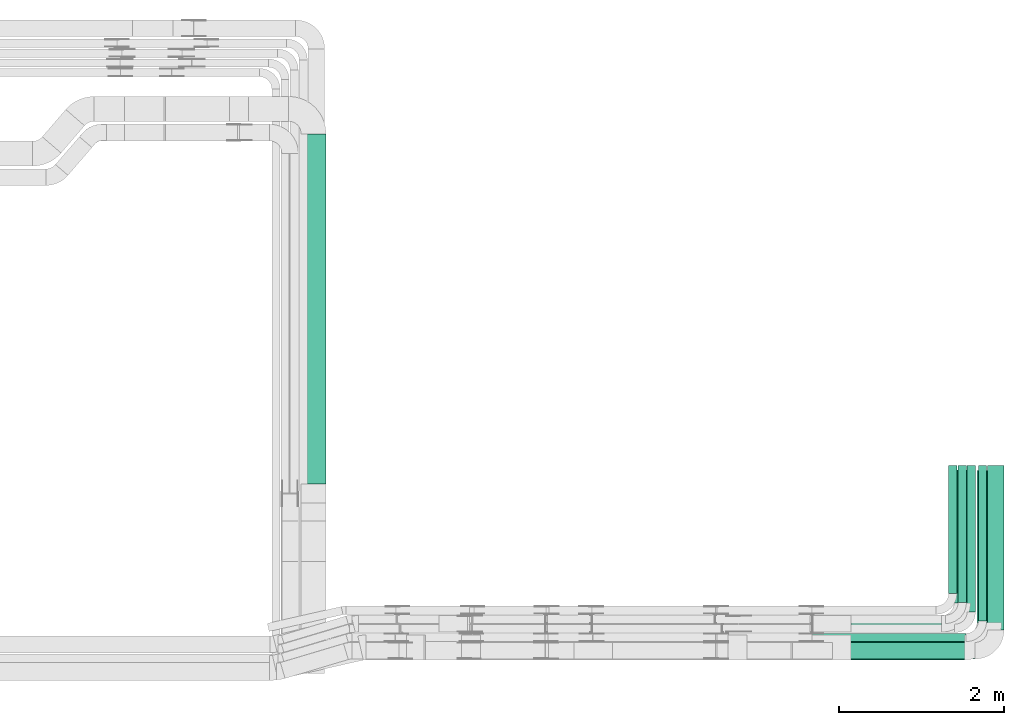
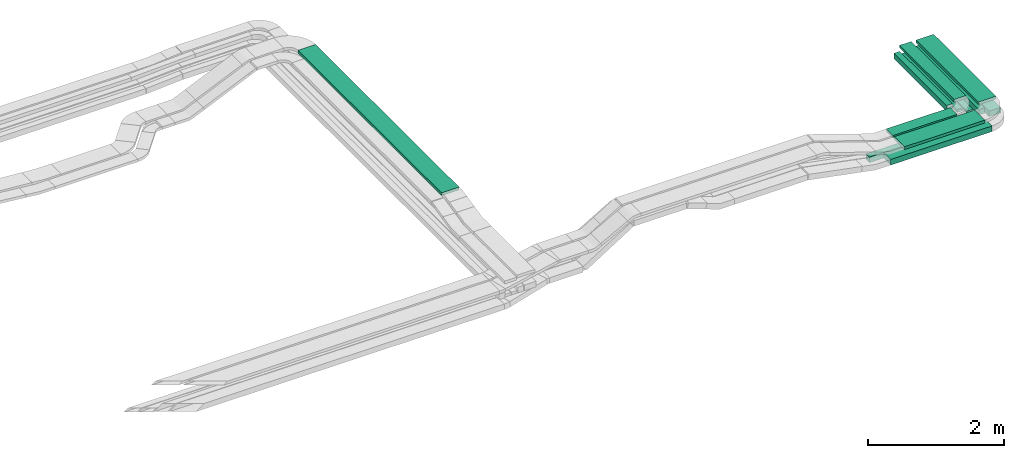
# One storey, part 3 of 28: 12 flow segments.
"""IFC2X3 building model written with IfcOpenShell, lengths in millimetres."""

from ifc_helpers import new_model, entity, si_unit, converted_unit, derived_unit, direction, frame, origin, origin_2d_with_axis, place, context, subcontext, project, spatial, rectangle, extrude, type_object, element, save


model = new_model("IFC2X3")

# Units and contexts
model_context = context("Model", 3, precision=0.01, world=origin(), true_north=direction((6.12303176911189e-17, 1.0)))
body_context = subcontext(model_context, "Body", "Model", "MODEL_VIEW")
ifc_project = project(units=[si_unit("LENGTHUNIT", "METRE", prefix="MILLI"), si_unit("AREAUNIT", "SQUARE_METRE"), si_unit("VOLUMEUNIT", "CUBIC_METRE"), converted_unit("PLANEANGLEUNIT", "DEGREE", entity("IfcRatioMeasure", 0.0174532925199433), si_unit("PLANEANGLEUNIT", "RADIAN"), dimensions=[0, 0, 0, 0, 0, 0, 0]), si_unit("MASSUNIT", "GRAM", prefix="KILO"), derived_unit("MASSDENSITYUNIT", [(si_unit("MASSUNIT", "GRAM", prefix="KILO"), 1), (si_unit("LENGTHUNIT", "METRE"), -3)]), derived_unit("MOMENTOFINERTIAUNIT", [(si_unit("LENGTHUNIT", "METRE"), 4)]), si_unit("TIMEUNIT", "SECOND"), si_unit("FREQUENCYUNIT", "HERTZ"), si_unit("THERMODYNAMICTEMPERATUREUNIT", "DEGREE_CELSIUS"), derived_unit("THERMALTRANSMITTANCEUNIT", [(si_unit("MASSUNIT", "GRAM", prefix="KILO"), 1), (si_unit("THERMODYNAMICTEMPERATUREUNIT", "KELVIN"), -1), (si_unit("TIMEUNIT", "SECOND"), -3)]), derived_unit("VOLUMETRICFLOWRATEUNIT", [(si_unit("LENGTHUNIT", "METRE"), 3), (si_unit("TIMEUNIT", "SECOND"), -1)]), derived_unit("MASSFLOWRATEUNIT", [(si_unit("MASSUNIT", "GRAM", prefix="KILO"), 1), (si_unit("TIMEUNIT", "SECOND"), -1)]), derived_unit("ROTATIONALFREQUENCYUNIT", [(si_unit("TIMEUNIT", "SECOND"), -1)]), si_unit("ELECTRICCURRENTUNIT", "AMPERE"), si_unit("ELECTRICVOLTAGEUNIT", "VOLT"), si_unit("POWERUNIT", "WATT"), si_unit("FORCEUNIT", "NEWTON", prefix="KILO"), si_unit("ILLUMINANCEUNIT", "LUX"), si_unit("LUMINOUSFLUXUNIT", "LUMEN"), si_unit("LUMINOUSINTENSITYUNIT", "CANDELA"), derived_unit("USERDEFINED", [(si_unit("MASSUNIT", "GRAM", prefix="KILO"), -1), (si_unit("LENGTHUNIT", "METRE"), -2), (si_unit("TIMEUNIT", "SECOND"), 3), (si_unit("LUMINOUSFLUXUNIT", "LUMEN"), 1)]), derived_unit("LINEARVELOCITYUNIT", [(si_unit("LENGTHUNIT", "METRE"), 1), (si_unit("TIMEUNIT", "SECOND"), -1)]), si_unit("PRESSUREUNIT", "PASCAL"), derived_unit("USERDEFINED", [(si_unit("LENGTHUNIT", "METRE"), -2), (si_unit("MASSUNIT", "GRAM", prefix="KILO"), 1), (si_unit("TIMEUNIT", "SECOND"), -2)]), derived_unit("LINEARFORCEUNIT", [(si_unit("MASSUNIT", "GRAM", prefix="KILO"), 1), (si_unit("LENGTHUNIT", "METRE"), 1), (si_unit("TIMEUNIT", "SECOND"), -2), (si_unit("LENGTHUNIT", "METRE"), -1)]), derived_unit("PLANARFORCEUNIT", [(si_unit("MASSUNIT", "GRAM", prefix="KILO"), 1), (si_unit("LENGTHUNIT", "METRE"), 1), (si_unit("TIMEUNIT", "SECOND"), -2), (si_unit("LENGTHUNIT", "METRE"), -2)])], contexts=[model_context])

# Site, building, storey
site_placement = place(None, origin())
site = spatial("IfcSite", under=ifc_project, at=site_placement, CompositionType="ELEMENT")
building_placement = place(site_placement, origin())
building = spatial("IfcBuilding", under=site, at=building_placement, CompositionType="ELEMENT")
storey_placement = place(building_placement, frame((0.0, 0.0, 15900.0)))
storey = spatial("IfcBuildingStorey", under=building, at=storey_placement, CompositionType="ELEMENT", Elevation=15900.0)

# Flow segments
cable_carrier_segment_type = type_object("IfcCableCarrierSegmentType", PredefinedType="CABLETRAYSEGMENT")
flow_segment_1_placement = place(storey_placement, frame((66901.69, 8474.97, 2595.87)))
element("IfcFlowSegment", 1, at=flow_segment_1_placement, inside=storey, type_object=cable_carrier_segment_type, context=body_context, shape_type="SweptSolid", body=[
    extrude(rectangle(XDim=1725.25554029387, YDim=200.0, at=origin_2d_with_axis()), frame((862.63, 100.0, 0.0), z_axis=(0.0, 0.0, 1.0), x_axis=(-1.0, 0.0, 0.0)), (0.0, 0.0, 1.0), 99.9999999999989),
])
flow_segment_2_placement = place(storey_placement, frame((67129.57, 8465.15, 2800.87)))
element("IfcFlowSegment", 2, at=flow_segment_2_placement, inside=storey, type_object=cable_carrier_segment_type, context=body_context, shape_type="SweptSolid", body=[
    extrude(rectangle(XDim=1369.62953868622, YDim=300.000000000001, at=origin_2d_with_axis()), frame((684.81, 150.0, 0.0)), (0.0, 0.0, 1.0), 50.0000000000016),
])
flow_segment_3_placement = place(storey_placement, frame((66660.32, 8684.97, 2595.87)))
element("IfcFlowSegment", 3, at=flow_segment_3_placement, inside=storey, type_object=cable_carrier_segment_type, context=body_context, shape_type="SweptSolid", body=[
    extrude(rectangle(XDim=1856.62032150398, YDim=99.9999999999989, at=origin_2d_with_axis()), frame((928.31, 50.0, 0.0), z_axis=(0.0, 0.0, 1.0), x_axis=(-1.0, 0.0, 0.0)), (0.0, 0.0, 1.0), 99.9999999999989),
])
flow_segment_4_placement = place(storey_placement, frame((68650.2, 8916.15, 2800.87)))
element("IfcFlowSegment", 4, at=flow_segment_4_placement, inside=storey, type_object=cable_carrier_segment_type, context=body_context, shape_type="SweptSolid", body=[
    extrude(rectangle(XDim=1839.00000000001, YDim=300.000000000001, at=origin_2d_with_axis()), frame((150.0, 919.5, 0.0), z_axis=(0.0, 0.0, 1.0), x_axis=(0.0, 1.0, 0.0)), (0.0, 0.0, 1.0), 50.0000000000038),
])
flow_segment_5_placement = place(storey_placement, frame((67129.73, 8800.15, 2800.87)))
element("IfcFlowSegment", 5, at=flow_segment_5_placement, inside=storey, type_object=cable_carrier_segment_type, context=body_context, shape_type="SweptSolid", body=[
    extrude(rectangle(XDim=1092.21867024738, YDim=200.0, at=origin_2d_with_axis()), frame((546.11, 100.0, 0.0)), (0.0, 0.0, 1.0), 50.0000000000016),
])
flow_segment_6_placement = place(storey_placement, frame((68372.94, 9151.15, 2800.87)))
element("IfcFlowSegment", 6, at=flow_segment_6_placement, inside=storey, type_object=cable_carrier_segment_type, context=body_context, shape_type="SweptSolid", body=[
    extrude(rectangle(XDim=1609.00000000001, YDim=200.000000000007, at=origin_2d_with_axis()), frame((100.0, 804.5, 0.0), z_axis=(0.0, 0.0, 1.0), x_axis=(0.0, 1.0, 0.0)), (0.0, 0.0, 1.0), 50.0000000000016),
])
flow_segment_7_placement = place(storey_placement, frame((60480.82, 10591.07, 3010.0)))
element("IfcFlowSegment", 7, at=flow_segment_7_placement, inside=storey, type_object=cable_carrier_segment_type, context=body_context, shape_type="SweptSolid", body=[
    extrude(rectangle(XDim=4232.95525920249, YDim=300.000000000001, at=origin_2d_with_axis()), frame((150.0, 2116.48, 0.0), z_axis=(0.0, 0.0, 1.0), x_axis=(0.0, -1.0, 0.0)), (0.0, 0.0, 1.0), 50.0000000000016),
])
flow_segment_8_placement = place(storey_placement, frame((68307.94, 9265.97, 2595.87)))
element("IfcFlowSegment", 8, at=flow_segment_8_placement, inside=storey, type_object=cable_carrier_segment_type, context=body_context, shape_type="SweptSolid", body=[
    extrude(rectangle(XDim=1548.99999999986, YDim=99.9999999999946, at=origin_2d_with_axis()), frame((50.0, 774.5, 0.0), z_axis=(0.0, 0.0, 1.0), x_axis=(0.0, 1.0, 0.0)), (0.0, 0.0, 1.0), 99.9999999999968),
])
flow_segment_9_placement = place(storey_placement, frame((68422.94, 9155.97, 2595.87)))
element("IfcFlowSegment", 9, at=flow_segment_9_placement, inside=storey, type_object=cable_carrier_segment_type, context=body_context, shape_type="SweptSolid", body=[
    extrude(rectangle(XDim=1658.99999999985, YDim=99.9999999999946, at=origin_2d_with_axis()), frame((50.0, 829.5, 0.0), z_axis=(0.0, 0.0, 1.0), x_axis=(0.0, 1.0, 0.0)), (0.0, 0.0, 1.0), 50.0000000000016),
])
flow_segment_10_placement = place(storey_placement, frame((68532.94, 9045.97, 2595.87)))
element("IfcFlowSegment", 10, at=flow_segment_10_placement, inside=storey, type_object=cable_carrier_segment_type, context=body_context, shape_type="SweptSolid", body=[
    extrude(rectangle(XDim=1768.99999999985, YDim=99.9999999999946, at=origin_2d_with_axis()), frame((50.0, 884.5, 0.0), z_axis=(0.0, 0.0, 1.0), x_axis=(0.0, 1.0, 0.0)), (0.0, 0.0, 1.0), 50.0000000000016),
])
flow_segment_11_placement = place(storey_placement, frame((68667.94, 8935.97, 2595.87)))
element("IfcFlowSegment", 11, at=flow_segment_11_placement, inside=storey, type_object=cable_carrier_segment_type, context=body_context, shape_type="SweptSolid", body=[
    extrude(rectangle(XDim=1878.99999999993, YDim=99.9999999999946, at=origin_2d_with_axis()), frame((50.0, 939.5, 0.0), z_axis=(0.0, 0.0, 1.0), x_axis=(0.0, 1.0, 0.0)), (0.0, 0.0, 1.0), 99.9999999999989),
])
flow_segment_12_placement = place(storey_placement, frame((68777.94, 8825.97, 2595.87)))
element("IfcFlowSegment", 12, at=flow_segment_12_placement, inside=storey, type_object=cable_carrier_segment_type, context=body_context, shape_type="SweptSolid", body=[
    extrude(rectangle(XDim=1989.00000000001, YDim=200.000000000007, at=origin_2d_with_axis()), frame((100.0, 994.5, 0.0), z_axis=(0.0, 0.0, 1.0), x_axis=(0.0, 1.0, 0.0)), (0.0, 0.0, 1.0), 99.9999999999989),
])

save(model, "model.ifc")
